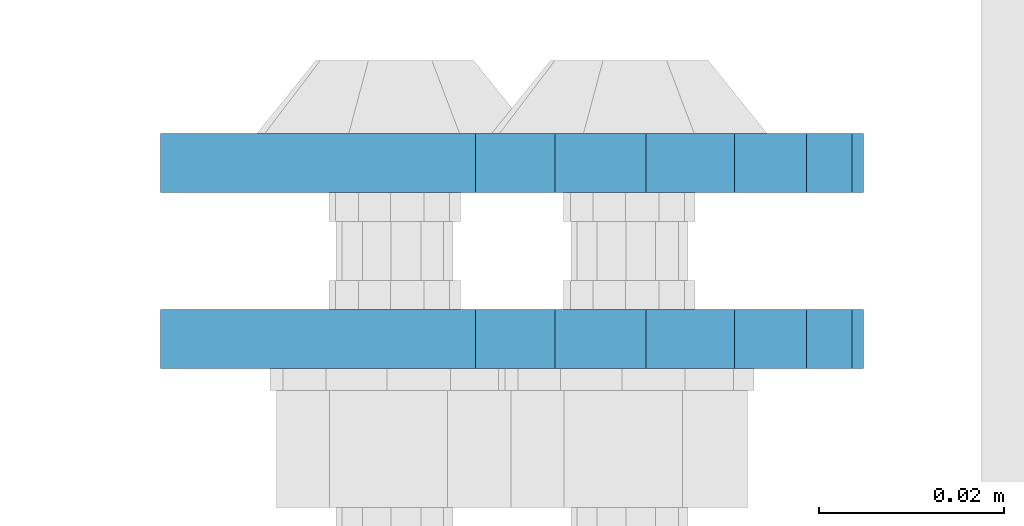
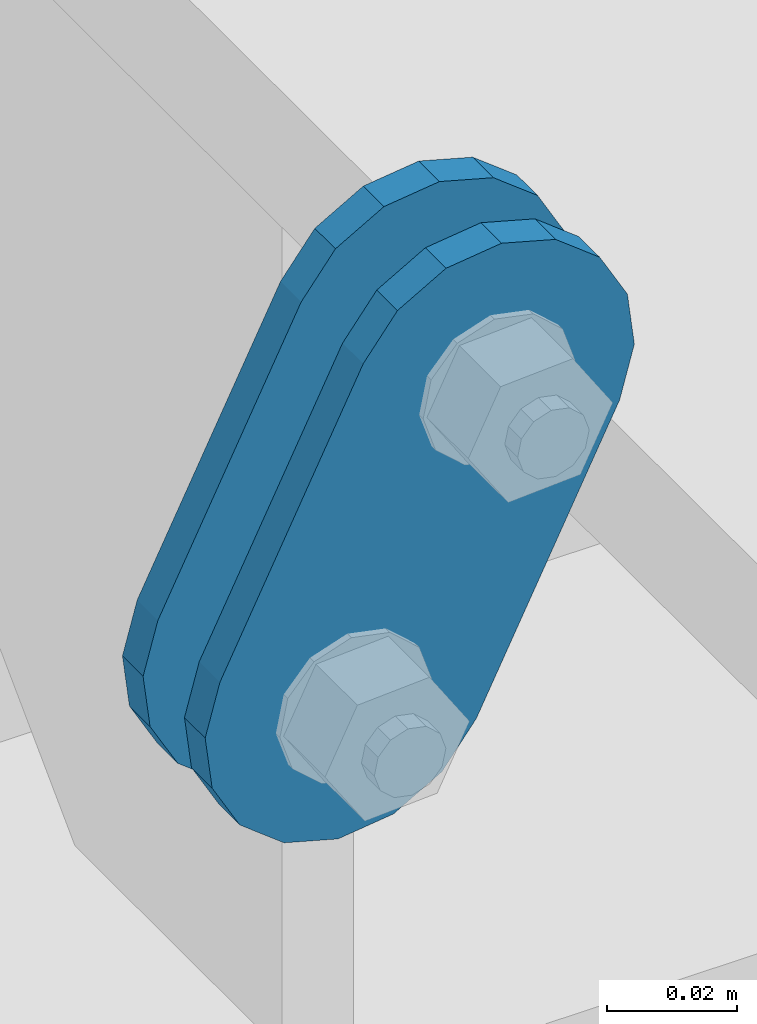
# One storey, part 1479 of 1876: 2 plates, 2 elements without a shape of their own.
"""IFC2X3 building model written with IfcOpenShell, lengths in millimetres."""

from ifc_helpers import new_model, si_unit, frame, origin_with_axes, place, context, subcontext, project, spatial, faceted_brep, material, type_object, element, aggregate, save


model = new_model("IFC2X3")

# Units and contexts
model_context = context("Model", 3, precision=1e-05, world=origin_with_axes())
body_context = subcontext(model_context, "Body", "Model", "MODEL_VIEW")
ifc_project = project(units=[si_unit("LENGTHUNIT", "METRE", prefix="MILLI"), si_unit("AREAUNIT", "SQUARE_METRE"), si_unit("VOLUMEUNIT", "CUBIC_METRE"), si_unit("MASSUNIT", "GRAM", prefix="KILO"), si_unit("TIMEUNIT", "SECOND"), si_unit("PLANEANGLEUNIT", "RADIAN"), si_unit("SOLIDANGLEUNIT", "STERADIAN"), si_unit("THERMODYNAMICTEMPERATUREUNIT", "DEGREE_CELSIUS"), si_unit("LUMINOUSINTENSITYUNIT", "LUMEN")], contexts=[model_context])

# Site, building, storey
site_placement = place(None, origin_with_axes())
site = spatial("IfcSite", under=ifc_project, at=site_placement, CompositionType="ELEMENT")
building_placement = place(site_placement, origin_with_axes())
building = spatial("IfcBuilding", under=site, at=building_placement, Name="Undefined", CompositionType="ELEMENT")
storey_placement = place(building_placement, origin_with_axes())
storey = spatial("IfcBuildingStorey", under=building, at=storey_placement, Name="Undefined", CompositionType="ELEMENT", Elevation=0.0)

# Assembly, plate
assembly_1_placement = place(storey_placement, origin_with_axes())
assembly_1 = element("IfcElementAssembly", 1, at=assembly_1_placement, inside=storey, Name="PLATE", AssemblyPlace="NOTDEFINED", PredefinedType="RIGID_FRAME")
ifc_material = material(Name="STEEL/A36")
plate_type = type_object("IfcPlateType", PredefinedType="NOTDEFINED")
plate_1_placement = place(assembly_1_placement, frame((-354.259224851122, -2549.5249946794, 7895.37767748094), z_axis=(0.894427191199916, 0.0, -0.447213595099958), x_axis=(-0.447213595099961, 6.99999707257306e-09, -0.894427191199915)))
plate_1 = element("IfcPlate", 2, at=plate_1_placement, type_object=plate_type, material=ifc_material, Name="PLATE", context=body_context, shape_type="Brep", body=[
    faceted_brep([(-8.59611645864788e-07, -3.17499999999654, 25.3999987589127), (1.93345873884391, -3.17499999999382, 35.1201580589886), (1.93345873884391, 3.17500000000564, 35.1201580589886), (-8.59611645864788e-07, 3.17500000000382, 25.3999987589132), (7.43948648259902, -3.17499999999109, 43.3605112870105), (7.43948648259902, 3.17500000000928, 43.3605112870105), (15.6798395242777, -3.17499999998654, 48.8665393096448), (15.6798395242777, 3.17500000001382, 48.8665393096448), (25.3999987589095, -3.17499999998199, 50.7999992370592), (25.3999987589095, 3.17500000001837, 50.7999992370592), (82.196130752618, -3.17499999998381, 50.7999992370605), (82.196130752618, 3.17500000001655, 50.7999992370642), (91.9162897887145, -3.17499999997926, 48.8665393918873), (91.9162897887145, 3.1750000000211, 48.8665393918909), (100.156642725027, -3.17499999997472, 43.3605115909359), (100.156642725027, 3.17500000002565, 43.3605115909395), (105.662670525982, -3.17499999997108, 35.1201586546285), (105.662670525986, 3.17500000002929, 35.1201586546358), (107.596130371159, -3.17499999996744, 25.3999996185757), (107.596130371159, 3.17500000003292, 25.3999996185794), (105.662670525981, -3.17499999996471, 15.6798405824902), (105.662670525981, 3.17500000003565, 15.6798405824939), (100.156642725024, -3.17499999996471, 7.43948764618654), (100.156642725025, 3.17500000003565, 7.43948764619017), (91.9162897887127, -3.17499999996562, 1.93345984522784), (91.9162897887127, 3.17500000003474, 1.93345984523148), (82.196130752618, -3.17499999996835, 4.54747350886464e-11), (82.196130752618, 3.1750000000311, 4.91127138957381e-11), (25.399998758905, -3.17499999999018, -8.64019966684282e-12), (25.399998758905, 3.17500000001019, -8.64019966684282e-12), (15.679839921364, -3.17499999999382, 1.9334597629304), (15.679839921364, 3.17500000000655, 1.9334597629304), (7.43948709043525, -3.17499999999654, 7.43948734220839), (7.43948709043525, 3.17500000000382, 7.43948734220885), (1.93345923228208, -3.17499999999654, 15.6798399868012), (1.93345923228208, 3.17500000000291, 15.6798399868012)], [[[0, 1, 2, 3]], [[1, 4, 5, 2]], [[4, 6, 7, 5]], [[6, 8, 9, 7]], [[8, 10, 11, 9]], [[10, 12, 13, 11]], [[12, 14, 15, 13]], [[14, 16, 17, 15]], [[16, 18, 19, 17]], [[18, 20, 21, 19]], [[20, 22, 23, 21]], [[22, 24, 25, 23]], [[24, 26, 27, 25]], [[26, 28, 29, 27]], [[28, 30, 31, 29]], [[30, 32, 33, 31]], [[32, 34, 35, 33]], [[34, 0, 3, 35]], [[5, 7, 9, 11, 13, 15, 17, 19, 21, 23, 25, 27, 29, 31, 33, 35, 3, 2]], [[34, 32, 30, 28, 26, 24, 22, 20, 18, 16, 14, 12, 10, 8, 6, 4, 1, 0]]]),
])
aggregate(assembly_1, [plate_1])

assembly_2_placement = place(storey_placement, origin_with_axes())
assembly_2 = element("IfcElementAssembly", 3, at=assembly_2_placement, inside=storey, Name="PLATE", AssemblyPlace="NOTDEFINED", PredefinedType="RIGID_FRAME")
plate_2_placement = place(assembly_2_placement, frame((-354.259224851122, -2530.46379837472, 7895.37767748094), z_axis=(0.894427191199916, 0.0, -0.447213595099958), x_axis=(-0.447213595099961, 6.99999707257306e-09, -0.894427191199915)))
plate_2 = element("IfcPlate", 4, at=plate_2_placement, type_object=plate_type, material=ifc_material, Name="PLATE", context=body_context, shape_type="Brep", body=[
    faceted_brep([(-8.59611645864788e-07, -3.17499999999654, 25.3999987589127), (1.93345873884391, -3.17499999999382, 35.1201580589886), (1.93345873884391, 3.17500000000564, 35.1201580589886), (-8.59611645864788e-07, 3.17500000000382, 25.3999987589132), (7.43948648259902, -3.17499999999109, 43.3605112870105), (7.43948648259902, 3.17500000000928, 43.3605112870105), (15.6798395242777, -3.17499999998654, 48.8665393096448), (15.6798395242777, 3.17500000001382, 48.8665393096448), (25.3999987589095, -3.17499999998199, 50.7999992370592), (25.3999987589095, 3.17500000001837, 50.7999992370592), (82.196130752618, -3.17499999998381, 50.7999992370605), (82.196130752618, 3.17500000001655, 50.7999992370642), (91.9162897887145, -3.17499999997926, 48.8665393918873), (91.9162897887145, 3.1750000000211, 48.8665393918909), (100.156642725027, -3.17499999997472, 43.3605115909359), (100.156642725027, 3.17500000002565, 43.3605115909395), (105.662670525982, -3.17499999997108, 35.1201586546285), (105.662670525986, 3.17500000002929, 35.1201586546358), (107.596130371159, -3.17499999996744, 25.3999996185757), (107.596130371159, 3.17500000003292, 25.3999996185794), (105.662670525981, -3.17499999996471, 15.6798405824902), (105.662670525981, 3.17500000003565, 15.6798405824939), (100.156642725024, -3.17499999996471, 7.43948764618654), (100.156642725025, 3.17500000003565, 7.43948764619017), (91.9162897887127, -3.17499999996562, 1.93345984522784), (91.9162897887127, 3.17500000003474, 1.93345984523148), (82.196130752618, -3.17499999996835, 4.54747350886464e-11), (82.196130752618, 3.1750000000311, 4.91127138957381e-11), (25.399998758905, -3.17499999999018, -8.64019966684282e-12), (25.399998758905, 3.17500000001019, -8.64019966684282e-12), (15.679839921364, -3.17499999999382, 1.9334597629304), (15.679839921364, 3.17500000000655, 1.9334597629304), (7.43948709043525, -3.17499999999654, 7.43948734220839), (7.43948709043525, 3.17500000000382, 7.43948734220885), (1.93345923228208, -3.17499999999654, 15.6798399868012), (1.93345923228208, 3.17500000000291, 15.6798399868012)], [[[0, 1, 2, 3]], [[1, 4, 5, 2]], [[4, 6, 7, 5]], [[6, 8, 9, 7]], [[8, 10, 11, 9]], [[10, 12, 13, 11]], [[12, 14, 15, 13]], [[14, 16, 17, 15]], [[16, 18, 19, 17]], [[18, 20, 21, 19]], [[20, 22, 23, 21]], [[22, 24, 25, 23]], [[24, 26, 27, 25]], [[26, 28, 29, 27]], [[28, 30, 31, 29]], [[30, 32, 33, 31]], [[32, 34, 35, 33]], [[34, 0, 3, 35]], [[5, 7, 9, 11, 13, 15, 17, 19, 21, 23, 25, 27, 29, 31, 33, 35, 3, 2]], [[34, 32, 30, 28, 26, 24, 22, 20, 18, 16, 14, 12, 10, 8, 6, 4, 1, 0]]]),
])
aggregate(assembly_2, [plate_2])

save(model, "model.ifc")
